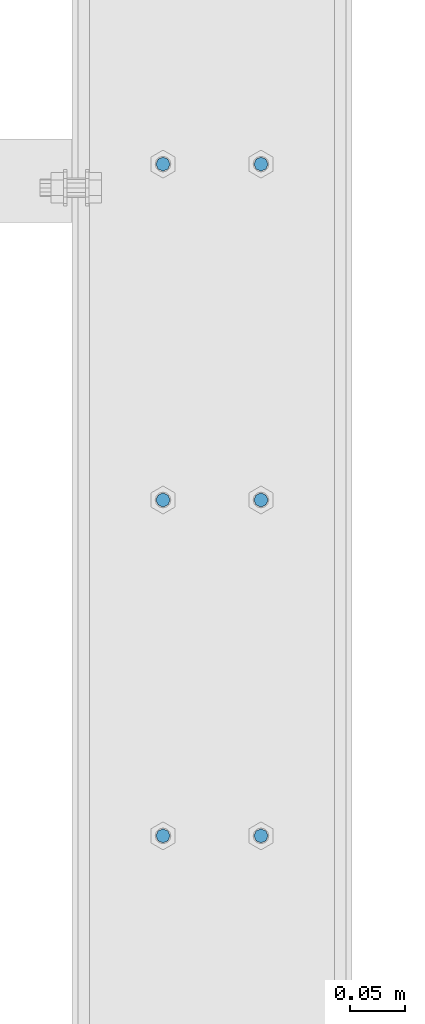
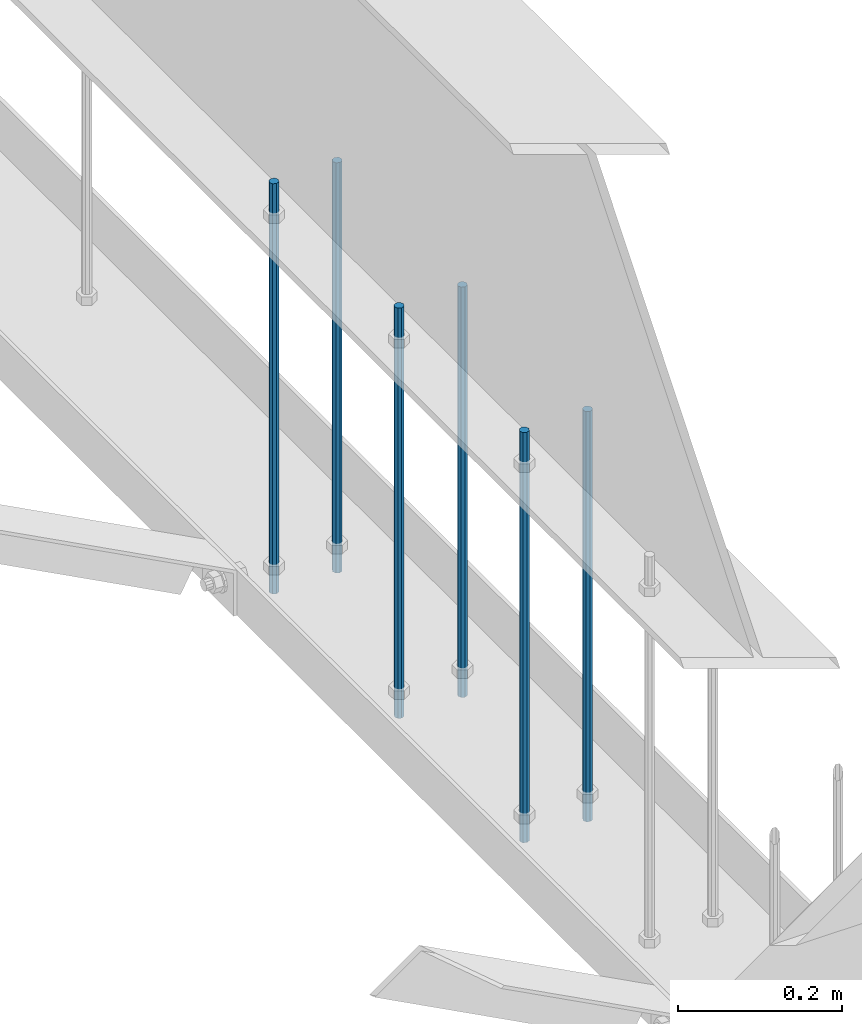
# One storey, part 223 of 975: 6 columns.
"""IFC2X3 building model written with IfcOpenShell, lengths in millimetres."""

from ifc_helpers import new_model, si_unit, frame, origin_with_axes, place, context, subcontext, project, spatial, faceted_brep, material, type_object, element, save


model = new_model("IFC2X3")

# Units and contexts
model_context = context("Model", 3, precision=1e-05, world=origin_with_axes())
body_context = subcontext(model_context, "Body", "Model", "MODEL_VIEW")
ifc_project = project(units=[si_unit("LENGTHUNIT", "METRE", prefix="MILLI"), si_unit("AREAUNIT", "SQUARE_METRE"), si_unit("VOLUMEUNIT", "CUBIC_METRE"), si_unit("MASSUNIT", "GRAM", prefix="KILO"), si_unit("TIMEUNIT", "SECOND"), si_unit("PLANEANGLEUNIT", "RADIAN"), si_unit("SOLIDANGLEUNIT", "STERADIAN"), si_unit("THERMODYNAMICTEMPERATUREUNIT", "DEGREE_CELSIUS"), si_unit("LUMINOUSINTENSITYUNIT", "LUMEN")], contexts=[model_context])

# Site, building, storey
site_placement = place(None, origin_with_axes())
site = spatial("IfcSite", under=ifc_project, at=site_placement, CompositionType="ELEMENT")
building_placement = place(site_placement, origin_with_axes())
building = spatial("IfcBuilding", under=site, at=building_placement, Name="Undefined", CompositionType="ELEMENT")
storey_placement = place(building_placement, origin_with_axes())
storey = spatial("IfcBuildingStorey", under=building, at=storey_placement, Name="Undefined", CompositionType="ELEMENT", Elevation=0.0)

# Columns
ifc_material = material(Name="STEEL/A36")
column_type = type_object("IfcColumnType", PredefinedType="NOTDEFINED")
for number, where, z_axis, x_axis, name in (
    (1, (8274.05, 22031.325, 2870.2), (-0.999999999999998, 6.90000001668524e-08, 0.0), (0.0, 0.0, 1.0), "ALL-THREAD ROD"),
    (2, (8274.05, 21726.525, 2870.2), (-0.999999999999998, 6.90000001668524e-08, 0.0), (0.0, 0.0, 1.0), "ALL-THREAD ROD"),
    (3, (8185.15, 21726.525, 2870.2), (-0.999999999999998, 6.90000001668524e-08, 0.0), (0.0, 0.0, 1.0), "ALL-THREAD ROD"),
    (4, (8185.15, 21421.725, 2870.2), (-0.999999999999998, 6.90000001668524e-08, 0.0), (0.0, 0.0, 1.0), "ALL-THREAD ROD"),
    (5, (8274.05, 21421.725, 2870.2), (-0.999999999999998, 6.90000001668524e-08, 0.0), (0.0, 0.0, 1.0), "ALL-THREAD ROD"),
    (6, (8185.15, 22031.325, 2870.2), (-0.999999999999998, 6.90000001668524e-08, 0.0), (0.0, 0.0, 1.0), "ALL-THREAD ROD"),
):
    element("IfcColumn", number, at=place(storey_placement, frame(where, z_axis=z_axis, x_axis=x_axis)), inside=storey, type_object=column_type, material=ifc_material, Name=name, context=body_context, shape_type="Brep", body=[
        faceted_brep([(0.0, -6.34999999998763, -3.63797880709171e-12), (0.0, -4.49012806052269, -4.49012806054634), (609.6, -4.49012806053361, -4.49012806053543), (609.6, -6.34999999999854, 0.0), (0.0, 7.27595761418343e-12, -6.35000000000764), (609.6, 0.0, -6.35000000000036), (0.0, 4.49012806053724, -4.49012806053906), (609.6, 4.49012806053361, -4.49012806053543), (0.0, 6.34999999999491, 5.45696821063757e-12), (609.6, 6.34999999999854, 0.0), (0.0, 4.49012806052633, 4.49012806054634), (609.6, 4.49012806053361, 4.49012806053543), (0.0, 0.0, 6.35000000000764), (609.6, 0.0, 6.35000000000036), (0.0, -4.49012806053361, 4.49012806053543), (609.6, -4.49012806053361, 4.49012806053543)], [[[0, 1, 2, 3]], [[1, 4, 5, 2]], [[4, 6, 7, 5]], [[6, 8, 9, 7]], [[8, 10, 11, 9]], [[10, 12, 13, 11]], [[12, 14, 15, 13]], [[14, 0, 3, 15]], [[5, 7, 9, 11, 13, 15, 3, 2]], [[14, 12, 10, 8, 6, 4, 1, 0]]]),
    ])

save(model, "model.ifc")
